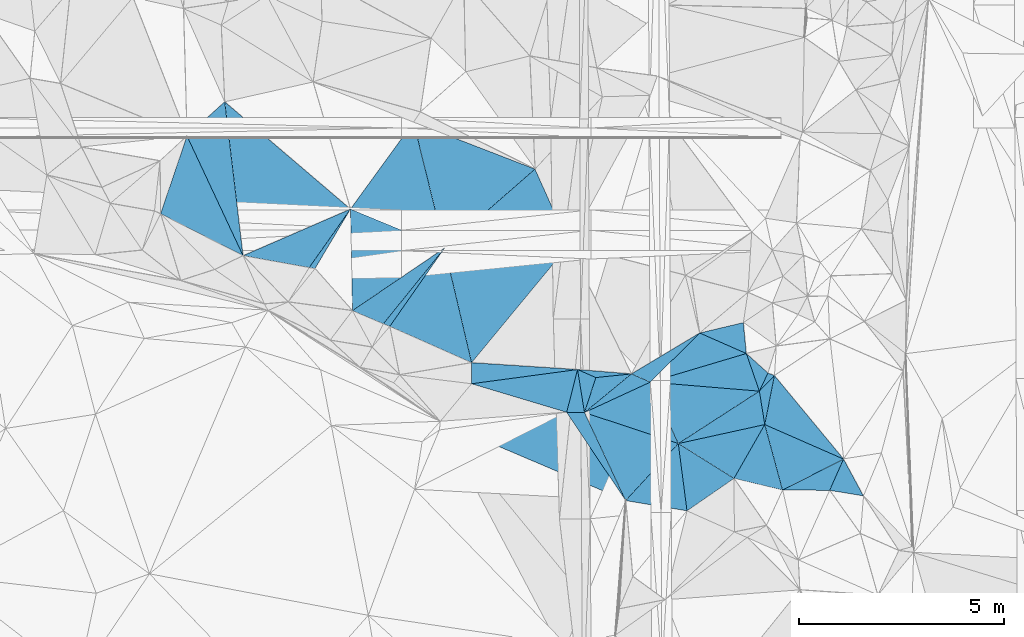
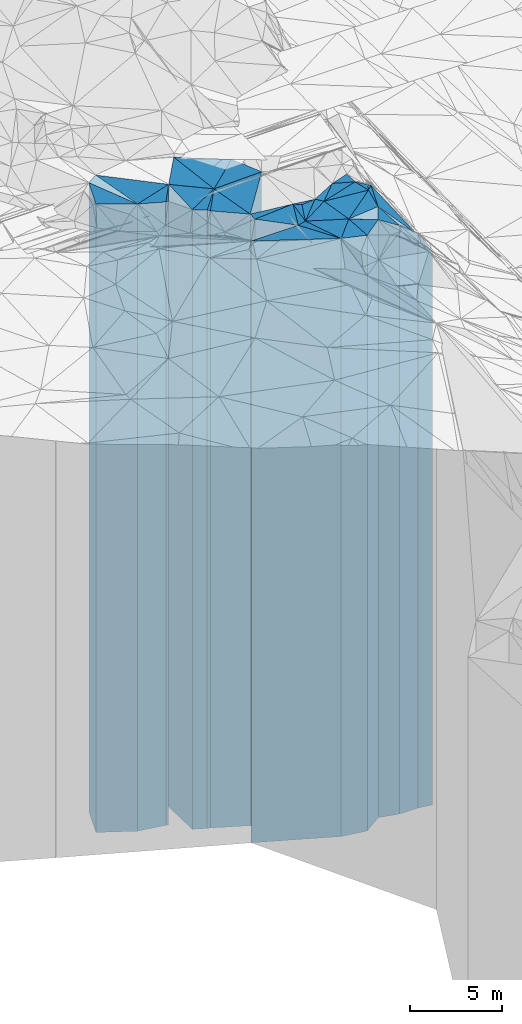
# One storey, part 209 of 275: 41 plates.
"""IFC2X3 building model written with IfcOpenShell, lengths in millimetres."""

from ifc_helpers import new_model, si_unit, frame, origin_with_axes, place, context, subcontext, project, spatial, faceted_brep, material, type_object, element, save


model = new_model("IFC2X3")

# Units and contexts
model_context = context("Model", 3, precision=1e-05, world=origin_with_axes())
body_context = subcontext(model_context, "Body", "Model", "MODEL_VIEW")
ifc_project = project(units=[si_unit("LENGTHUNIT", "METRE", prefix="MILLI"), si_unit("AREAUNIT", "SQUARE_METRE"), si_unit("VOLUMEUNIT", "CUBIC_METRE"), si_unit("MASSUNIT", "GRAM", prefix="KILO"), si_unit("TIMEUNIT", "SECOND"), si_unit("PLANEANGLEUNIT", "RADIAN"), si_unit("SOLIDANGLEUNIT", "STERADIAN"), si_unit("THERMODYNAMICTEMPERATUREUNIT", "DEGREE_CELSIUS"), si_unit("LUMINOUSINTENSITYUNIT", "LUMEN")], contexts=[model_context])

# Site, building, storey
site_placement = place(None, origin_with_axes())
site = spatial("IfcSite", under=ifc_project, at=site_placement, CompositionType="ELEMENT")
building_placement = place(site_placement, origin_with_axes())
building = spatial("IfcBuilding", under=site, at=building_placement, Name="Undefined", CompositionType="ELEMENT")
storey_placement = place(building_placement, origin_with_axes())
storey = spatial("IfcBuildingStorey", under=building, at=storey_placement, Name="Undefined", CompositionType="ELEMENT", Elevation=0.0)

# Plates
ifc_material = material()
plate_type_1 = type_object("IfcPlateType", PredefinedType="NOTDEFINED")
plate_1_placement = place(storey_placement, frame((-114424.275209468, 60931.8089571276, 28569.0), z_axis=(0.670976266904861, -0.741478825894857, 0.0), x_axis=(-0.741478825894864, -0.670976266904855, 0.0)))
element("IfcPlate", 1, at=plate_1_placement, inside=storey, type_object=plate_type_1, material=ifc_material, Name="00", context=body_context, shape_type="Brep", body=[
    faceted_brep([(1.45519152283669e-11, -20741.0, -1.45519152283669e-11), (2189.93041992193, -20941.0, 3088.80297851561), (2189.93041992193, 20741.0, 3088.80297851561), (1.45519152283669e-11, 20741.0, -1.45519152283669e-11), (1242.7791748047, -21071.0, 5.67524693906307e-10), (1242.7791748047, 20741.0, 5.67524693906307e-10)], [[[0, 1, 2, 3]], [[1, 4, 5, 2]], [[4, 0, 3, 5]], [[5, 3, 2]], [[4, 1, 0]]]),
])
plate_type_2 = type_object("IfcPlateType", PredefinedType="NOTDEFINED")
plate_2_placement = place(storey_placement, frame((-112359.67016511, 56880.6972565187, 28519.0), z_axis=(0.170841814937065, 0.985298469636998, 0.0), x_axis=(0.985298469637004, -0.17084181493703, 0.0)))
element("IfcPlate", 2, at=plate_2_placement, inside=storey, type_object=plate_type_2, material=ifc_material, Name="00", context=body_context, shape_type="Brep", body=[
    faceted_brep([(1.45519152283669e-11, -20741.0, -1.45519152283669e-11), (748.845275878848, -20691.0, 1580.89550781251), (748.845275878848, 20691.0, 1580.89550781251), (0.0, 20691.0, 0.0), (144.222045898438, -20761.0, -5.45696821063757e-10), (144.222045898438, 20691.0, -5.45696821063757e-10)], [[[0, 1, 2, 3]], [[1, 4, 5, 2]], [[4, 0, 3, 5]], [[5, 3, 2]], [[4, 1, 0]]]),
])
plate_type_3 = type_object("IfcPlateType", PredefinedType="NOTDEFINED")
plate_3_placement = place(storey_placement, frame((-106011.673109198, 57435.1640076748, 28254.0), z_axis=(-0.912580697493601, -0.408896650221169, 0.0), x_axis=(-0.408896650221169, 0.912580697493601, 0.0)))
element("IfcPlate", 3, at=plate_3_placement, inside=storey, type_object=plate_type_3, material=ifc_material, Name="00", context=body_context, shape_type="Brep", body=[
    faceted_brep([(0.0, -20456.0, 1.45519152283669e-11), (1173.828125, -20426.0, 2804.25170898436), (1173.828125, 20426.0, 2804.25170898436), (0.0, 20426.0, 1.45519152283669e-11), (2030.02465820313, -20456.0, -2.7648638933897e-09), (2030.02465820313, 20426.0, -2.7648638933897e-09)], [[[0, 1, 2, 3]], [[1, 4, 5, 2]], [[4, 0, 3, 5]], [[5, 3, 2]], [[4, 1, 0]]]),
])
plate_type_4 = type_object("IfcPlateType", PredefinedType="NOTDEFINED")
plate_4_placement = place(storey_placement, frame((-109809.448700942, 60435.6473945233, 28254.0), z_axis=(0.809337018100114, -0.58734452507265, 0.0), x_axis=(-0.587344525072653, -0.809337018100111, 0.0)))
element("IfcPlate", 4, at=plate_4_placement, inside=storey, type_object=plate_type_4, material=ifc_material, Name="00", context=body_context, shape_type="Brep", body=[
    faceted_brep([(9.09494701772928e-12, -20936.0, -1.45519152283669e-11), (2043.84008789064, -20426.0, 2420.66479492188), (2043.84008789064, 20426.0, 2420.66479492188), (0.0, 20426.0, 1.45519152283669e-11), (2625.89038085938, -20956.0, 9.66247171163559e-09), (2625.89038085938, 20426.0, 9.66247171163559e-09)], [[[0, 1, 2, 3]], [[1, 4, 5, 2]], [[4, 0, 3, 5]], [[5, 3, 2]], [[4, 1, 0]]]),
])
plate_type_5 = type_object("IfcPlateType", PredefinedType="NOTDEFINED")
plate_5_placement = place(storey_placement, frame((-108391.041459215, 54557.1253951925, 28149.0), z_axis=(-0.77071736266349, 0.637177170721797, 0.0), x_axis=(0.637177170721798, 0.770717362663489, 0.0)))
element("IfcPlate", 5, at=plate_5_placement, inside=storey, type_object=plate_type_5, material=ifc_material, Name="00", context=body_context, shape_type="Brep", body=[
    faceted_brep([(0.0, -20321.0, 0.0), (1739.66088867188, -20531.0, 2294.20581054689), (1739.66088867188, 20321.0, 2294.20581054689), (0.0, 20321.0, 0.0), (3734.23364257813, -20561.0, 7.71251507103443e-09), (3734.23364257813, 20321.0, 7.71251507103443e-09)], [[[0, 1, 2, 3]], [[1, 4, 5, 2]], [[4, 0, 3, 5]], [[5, 3, 2]], [[4, 1, 0]]]),
])
plate_type_6 = type_object("IfcPlateType", PredefinedType="NOTDEFINED")
plate_6_placement = place(storey_placement, frame((-113975.54879864, 57172.1354861696, 28519.0), z_axis=(-0.397990849921517, 0.91738938481909, 0.0), x_axis=(0.91738938481909, 0.397990849921517, 0.0)))
element("IfcPlate", 6, at=plate_6_placement, inside=storey, type_object=plate_type_6, material=ifc_material, Name="00", context=body_context, shape_type="Brep", body=[
    faceted_brep([(-1.45519152283669e-11, -20991.0, 0.0), (1084.65881347655, -20791.0, 3627.67358398439), (1084.65881347655, 20691.0, 3627.67358398439), (0.0, 20691.0, 0.0), (2860.06982421874, -20691.0, 3.23052518069744e-09), (2860.06982421874, 20691.0, 3.23052518069744e-09)], [[[0, 1, 2, 3]], [[1, 4, 5, 2]], [[4, 0, 3, 5]], [[5, 3, 2]], [[4, 1, 0]]]),
])
plate_type_7 = type_object("IfcPlateType", PredefinedType="NOTDEFINED")
plate_7_placement = place(storey_placement, frame((-104025.95095473, 54081.746717021, 27959.0), z_axis=(-0.285407885057941, 0.95840614519459, 0.0), x_axis=(0.958406145194588, 0.285407885057947, 0.0)))
element("IfcPlate", 7, at=plate_7_placement, inside=storey, type_object=plate_type_7, material=ifc_material, Name="00", context=body_context, shape_type="Brep", body=[
    faceted_brep([(0.0, -20131.0, 7.27595761418343e-12), (1500.02416992188, -20161.0, 806.304809570313), (1500.02416992188, 20131.0, 806.304809570313), (1.45519152283669e-11, 20131.0, 0.0), (2449.69384765626, -20171.0, 1.89174897968769e-10), (2449.69384765626, 20131.0, 1.89174897968769e-10)], [[[0, 1, 2, 3]], [[1, 4, 5, 2]], [[4, 0, 3, 5]], [[5, 3, 2]], [[4, 1, 0]]]),
])
plate_type_8 = type_object("IfcPlateType", PredefinedType="NOTDEFINED")
plate_8_placement = place(storey_placement, frame((-101359.051632054, 53861.41060398, 27929.0), z_axis=(-0.904147253795478, 0.427220953903359, 0.0), x_axis=(0.42722095390336, 0.904147253795477, 0.0)))
element("IfcPlate", 8, at=plate_8_placement, inside=storey, type_object=plate_type_8, material=ifc_material, Name="00", context=body_context, shape_type="Brep", body=[
    faceted_brep([(-1.18234311230481e-11, -20101.0, 0.0), (695.036437988269, -20201.0, 681.340148925781), (695.036437988269, 20101.0, 681.340148925781), (-1.18234311230481e-11, 20101.0, 0.0), (489.182983398433, -20131.0, -1.64436642080545e-09), (489.182983398433, 20101.0, -1.64436642080545e-09)], [[[0, 1, 2, 3]], [[1, 4, 5, 2]], [[4, 0, 3, 5]], [[5, 3, 2]], [[4, 1, 0]]]),
])
plate_type_9 = type_object("IfcPlateType", PredefinedType="NOTDEFINED")
plate_9_placement = place(storey_placement, frame((-101749.814494169, 55536.464151062, 27974.0), z_axis=(0.231099677077141, -0.972930079324738, 0.0), x_axis=(-0.97293007932474, -0.231099677077134, 0.0)))
element("IfcPlate", 9, at=plate_9_placement, inside=storey, type_object=plate_type_9, material=ifc_material, Name="00", context=body_context, shape_type="Brep", body=[
    faceted_brep([(0.0, -20246.0, 0.0), (104.883415222153, -20156.0, 751.664489746079), (104.883415222153, 20146.0, 751.664489746079), (2.91038304567337e-11, 20146.0, 1.09139364212751e-11), (1098.3624267578, -20146.0, 3.65253072232008e-09), (1098.3624267578, 20146.0, 3.66708263754845e-09)], [[[0, 1, 2, 3]], [[1, 4, 5, 2]], [[4, 0, 3, 5]], [[5, 3, 2]], [[4, 1, 0]]]),
])
plate_type_10 = type_object("IfcPlateType", PredefinedType="NOTDEFINED")
plate_10_placement = place(storey_placement, frame((-101227.597226745, 53044.8202909558, 26614.0), z_axis=(0.401196459925375, 0.915992030829607, 0.0), x_axis=(0.915992030829608, -0.401196459925371, 0.0)))
element("IfcPlate", 10, at=plate_10_placement, inside=storey, type_object=plate_type_10, material=ifc_material, Name="00", context=body_context, shape_type="Brep", body=[
    faceted_brep([(-1.45519152283669e-11, -20766.0, -1.45519152283669e-11), (-264.495147705093, -21386.0, 1191.65527343749), (-264.495147705093, 18786.0, 1191.65527343749), (0.0, 18786.0, -1.81898940354586e-12), (2102.11791992186, -18786.0, 4.60750015918165e-09), (2102.11791992186, 18786.0, 4.60750015918165e-09)], [[[0, 1, 2, 3]], [[1, 4, 5, 2]], [[4, 0, 3, 5]], [[5, 3, 2]], [[4, 1, 0]]]),
])
plate_type_11 = type_object("IfcPlateType", PredefinedType="NOTDEFINED")
plate_11_placement = place(storey_placement, frame((-101678.149306749, 54780.9086594453, 27929.0), z_axis=(0.285407885057941, -0.95840614519459, 0.0), x_axis=(-0.958406145194588, -0.285407885057947, 0.0)))
element("IfcPlate", 11, at=plate_11_placement, inside=storey, type_object=plate_type_11, material=ifc_material, Name="00", context=body_context, shape_type="Brep", body=[
    faceted_brep([(-7.27595761418343e-12, -20201.0, 0.0), (-43.3931770324853, -20101.0, 972.325561523423), (-43.3931770324853, 20101.0, 972.325561523423), (-1.18234311230481e-11, 20101.0, 0.0), (2449.69384765624, -20161.0, 2.18278728425503e-10), (2449.69384765624, 20101.0, 2.18278728425503e-10)], [[[0, 1, 2, 3]], [[1, 4, 5, 2]], [[4, 0, 3, 5]], [[5, 3, 2]], [[4, 1, 0]]]),
])
plate_type_12 = type_object("IfcPlateType", PredefinedType="NOTDEFINED")
plate_12_placement = place(storey_placement, frame((-113975.54879864, 57172.1354861696, 28519.0), z_axis=(0.177495184991706, 0.984121668953976, 0.0), x_axis=(0.984121668953977, -0.177495184991705, 0.0)))
element("IfcPlate", 12, at=plate_12_placement, inside=storey, type_object=plate_type_12, material=ifc_material, Name="00", context=body_context, shape_type="Brep", body=[
    faceted_brep([(-1.45519152283669e-11, -20991.0, 0.0), (2380.09667968749, -20691.0, 1585.91906738281), (2380.09667968749, 20691.0, 1585.91906738281), (0.0, 20691.0, 0.0), (1641.95007324217, -20741.0, 3.18686943501234e-09), (1641.95007324217, 20691.0, 3.18686943501234e-09)], [[[0, 1, 2, 3]], [[1, 4, 5, 2]], [[4, 0, 3, 5]], [[5, 3, 2]], [[4, 1, 0]]]),
])
plate_type_13 = type_object("IfcPlateType", PredefinedType="NOTDEFINED")
plate_13_placement = place(storey_placement, frame((-109050.753459271, 57359.7277710179, 28254.0), z_axis=(-0.381855316813604, -0.924222114548869, 0.0), x_axis=(-0.924222114548867, 0.381855316813607, 0.0)))
element("IfcPlate", 13, at=plate_13_placement, inside=storey, type_object=plate_type_13, material=ifc_material, Name="00", context=body_context, shape_type="Brep", body=[
    faceted_brep([(0.0, -20426.0, -1.45519152283669e-11), (1497.2333984375, -20766.0, 2276.13525390625), (1497.2333984375, 20426.0, 2276.13525390625), (0.0, 20426.0, 1.45519152283669e-11), (2489.65869140625, -20956.0, -4.47471393272281e-09), (2489.65869140625, 20426.0, -4.47471393272281e-09)], [[[0, 1, 2, 3]], [[1, 4, 5, 2]], [[4, 0, 3, 5]], [[5, 3, 2]], [[4, 1, 0]]]),
])
plate_type_14 = type_object("IfcPlateType", PredefinedType="NOTDEFINED")
plate_14_placement = place(storey_placement, frame((-103340.405427795, 52580.7712573621, 27604.0), z_axis=(-0.2145227860623, 0.976718984283642, 0.0), x_axis=(0.976718984283642, 0.214522786062299, 0.0)))
element("IfcPlate", 14, at=plate_14_placement, inside=storey, type_object=plate_type_14, material=ifc_material, Name="00", context=body_context, shape_type="Brep", body=[
    faceted_brep([(-1.45519152283669e-11, -19976.0, 0.0), (2209.9521484375, -20426.0, 825.779235839844), (2209.9521484375, 19776.0, 825.779235839844), (-1.45519152283669e-11, 19776.0, 0.0), (2163.16894531249, -19776.0, -3.36149241775274e-09), (2163.16894531249, 19776.0, -3.36149241775274e-09)], [[[0, 1, 2, 3]], [[1, 4, 5, 2]], [[4, 0, 3, 5]], [[5, 3, 2]], [[4, 1, 0]]]),
])
plate_type_15 = type_object("IfcPlateType", PredefinedType="NOTDEFINED")
plate_15_placement = place(storey_placement, frame((-101359.051632054, 53861.41060398, 27604.0), z_axis=(0.987289296012235, 0.158933464001971, 0.0), x_axis=(0.158933464001974, -0.987289296012234, 0.0)))
element("IfcPlate", 15, at=plate_15_placement, inside=storey, type_object=plate_type_15, material=ifc_material, Name="00", context=body_context, shape_type="Brep", body=[
    faceted_brep([(0.0, -20426.0, -1.45519152283669e-11), (-317.856262207046, -20396.0, 423.163543701157), (-317.856262207046, 19776.0, 423.163543701157), (-1.45519152283669e-11, 19776.0, 0.0), (827.103393554673, -19776.0, -1.86264514923096e-09), (827.103393554673, 19776.0, -1.86264514923096e-09)], [[[0, 1, 2, 3]], [[1, 4, 5, 2]], [[4, 0, 3, 5]], [[5, 3, 2]], [[4, 1, 0]]]),
])
plate_type_16 = type_object("IfcPlateType", PredefinedType="NOTDEFINED")
plate_16_placement = place(storey_placement, frame((-100793.03330737, 51443.8036764334, 26614.0), z_axis=(-0.453027820121401, 0.891496379238891, 0.0), x_axis=(0.891496379238891, 0.4530278201214, 0.0)))
element("IfcPlate", 16, at=plate_16_placement, inside=storey, type_object=plate_type_16, material=ifc_material, Name="00", context=body_context, shape_type="Brep", body=[
    faceted_brep([(-1.45519152283669e-11, -20316.0, 0.0), (337.892913818359, -20766.0, 1624.17004394531), (337.892913818359, 18786.0, 1624.17004394531), (0.0, 18786.0, -1.81898940354586e-12), (1672.42333984375, -18786.0, -1.94995664060116e-09), (1672.42333984375, 18786.0, -1.94995664060116e-09)], [[[0, 1, 2, 3]], [[1, 4, 5, 2]], [[4, 0, 3, 5]], [[5, 3, 2]], [[4, 1, 0]]]),
])
plate_type_17 = type_object("IfcPlateType", PredefinedType="NOTDEFINED")
plate_17_placement = place(storey_placement, frame((-100991.784790361, 54242.4815514324, 27914.0), z_axis=(-0.360757109901238, -0.932659802744659, 0.0), x_axis=(-0.932659802744667, 0.360757109901216, 0.0)))
element("IfcPlate", 17, at=plate_17_placement, inside=storey, type_object=plate_type_17, material=ifc_material, Name="00", context=body_context, shape_type="Brep", body=[
    faceted_brep([(0.0, -20086.0, 0.0), (205.060974121079, -20116.0, 487.903686523438), (205.060974121079, 20086.0, 487.903686523438), (0.0, 20086.0, 0.0), (169.705627441406, -20146.0, 6.83940015733242e-10), (169.705627441406, 20086.0, 6.83940015733242e-10)], [[[0, 1, 2, 3]], [[1, 4, 5, 2]], [[4, 0, 3, 5]], [[5, 3, 2]], [[4, 1, 0]]]),
])
plate_type_18 = type_object("IfcPlateType", PredefinedType="NOTDEFINED")
plate_18_placement = place(storey_placement, frame((-99302.0739093872, 52201.4579997015, 26614.0), z_axis=(0.453027820121401, -0.891496379238891, 0.0), x_axis=(-0.891496379238893, -0.453027820121396, 0.0)))
element("IfcPlate", 18, at=plate_18_placement, inside=storey, type_object=plate_type_18, material=ifc_material, Name="00", context=body_context, shape_type="Brep", body=[
    faceted_brep([(0.0, -18786.0, 0.0), (649.237487792961, -19366.0, 525.823791503906), (649.237487792961, 18786.0, 525.823791503906), (0.0, 18786.0, -1.81898940354586e-12), (1672.42333984374, -20316.0, -1.96450855582953e-09), (1672.42333984375, 18786.0, -1.94995664060116e-09)], [[[0, 1, 2, 3]], [[1, 4, 5, 2]], [[4, 0, 3, 5]], [[5, 3, 2]], [[4, 1, 0]]]),
])
plate_type_19 = type_object("IfcPlateType", PredefinedType="NOTDEFINED")
plate_19_placement = place(storey_placement, frame((-105632.632516036, 53338.5277986937, 27704.0), z_axis=(0.313871074084043, 0.949465612254246, 0.0), x_axis=(0.949465612254244, -0.313871074084048, 0.0)))
element("IfcPlate", 19, at=plate_19_placement, inside=storey, type_object=plate_type_19, material=ifc_material, Name="00", context=body_context, shape_type="Brep", body=[
    faceted_brep([(0.0, -20076.0, 0.0), (1292.21398925783, -20386.0, 1209.95166015625), (1292.21398925783, 19876.0, 1209.95166015625), (1.45519152283669e-11, 19876.0, 3.63797880709171e-12), (2414.22875976564, -19876.0, -6.62475940771401e-09), (2414.22875976564, 19876.0, -6.62475940771401e-09)], [[[0, 1, 2, 3]], [[1, 4, 5, 2]], [[4, 0, 3, 5]], [[5, 3, 2]], [[4, 1, 0]]]),
])
plate_type_20 = type_object("IfcPlateType", PredefinedType="NOTDEFINED")
plate_20_placement = place(storey_placement, frame((-102818.444328002, 55282.6329507697, 27959.0), z_axis=(0.514166750066084, -0.857690243110227, 0.0), x_axis=(-0.85769024311023, -0.51416675006608, 0.0)))
element("IfcPlate", 20, at=plate_20_placement, inside=storey, type_object=plate_type_20, material=ifc_material, Name="00", context=body_context, shape_type="Brep", body=[
    faceted_brep([(-3.63797880709171e-12, -20161.0, 0.0), (1653.12243652342, -20131.0, 409.128662109375), (1653.12243652342, 20131.0, 409.128662109375), (1.45519152283669e-11, 20131.0, 0.0), (1944.86499023438, -20301.0, 1.0986695997417e-08), (1944.86499023438, 20131.0, 1.0986695997417e-08)], [[[0, 1, 2, 3]], [[1, 4, 5, 2]], [[4, 0, 3, 5]], [[5, 3, 2]], [[4, 1, 0]]]),
])
plate_type_21 = type_object("IfcPlateType", PredefinedType="NOTDEFINED")
plate_21_placement = place(storey_placement, frame((-105632.632516036, 53338.5277986937, 27804.0), z_axis=(-0.951100424197907, 0.308881827064269, 0.0), x_axis=(0.308881827064278, 0.951100424197904, 0.0)))
element("IfcPlate", 21, at=plate_21_placement, inside=storey, type_object=plate_type_21, material=ifc_material, Name="00", context=body_context, shape_type="Brep", body=[
    faceted_brep([(-1.45519152283669e-11, -19976.0, 0.0), (947.421325683605, -20536.0, 485.996765136719), (947.421325683605, 19976.0, 485.996765136719), (1.09139364212751e-11, 19976.0, 0.0), (899.388671875007, -20456.0, -2.21189111471176e-09), (899.388671875007, 19976.0, -2.21189111471176e-09)], [[[0, 1, 2, 3]], [[1, 4, 5, 2]], [[4, 0, 3, 5]], [[5, 3, 2]], [[4, 1, 0]]]),
])
plate_type_22 = type_object("IfcPlateType", PredefinedType="NOTDEFINED")
plate_22_placement = place(storey_placement, frame((-105802.223031823, 54389.7361781101, 27740.0), z_axis=(0.969370848409617, -0.245601625103783, 0.0), x_axis=(-0.245601625103788, -0.969370848409616, 0.0)))
element("IfcPlate", 22, at=plate_22_placement, inside=storey, type_object=plate_type_22, material=ifc_material, Name="00", context=body_context, shape_type="Brep", body=[
    faceted_brep([(-7.27595761418343e-12, -20600.0, -2.91038304567337e-11), (977.359069824219, -20040.0, 422.574584960908), (977.359069824219, 19912.0, 422.574584960908), (-7.27595761418343e-12, 19912.0, -2.91038304567337e-11), (1078.43688964843, -19912.0, -6.83940015733242e-10), (1078.43688964843, 19912.0, -6.83940015733242e-10)], [[[0, 1, 2, 3]], [[1, 4, 5, 2]], [[4, 0, 3, 5]], [[5, 3, 2]], [[4, 1, 0]]]),
])
plate_type_23 = type_object("IfcPlateType", PredefinedType="NOTDEFINED")
plate_23_placement = place(storey_placement, frame((-105802.223031823, 54389.7361781101, 28044.0), z_axis=(0.400928765088184, 0.916109232201523, 0.0), x_axis=(0.91610923220154, -0.400928765088145, 0.0)))
element("IfcPlate", 23, at=plate_23_placement, inside=storey, type_object=plate_type_23, material=ifc_material, Name="00", context=body_context, shape_type="Brep", body=[
    faceted_brep([(-1.45519152283669e-11, -20296.0, 9.09494701772928e-12), (1248.24768066405, -20216.0, 429.392272949235), (1248.24768066405, 20216.0, 429.392272949235), (0.0, 20216.0, 0.0), (488.364624023423, -20216.0, -2.49383447226137e-09), (488.364624023423, 20216.0, -2.49383447226137e-09)], [[[0, 1, 2, 3]], [[1, 4, 5, 2]], [[4, 0, 3, 5]], [[5, 3, 2]], [[4, 1, 0]]]),
])
plate_type_24 = type_object("IfcPlateType", PredefinedType="NOTDEFINED")
plate_24_placement = place(storey_placement, frame((-101227.597226745, 53044.8202909558, 27379.0), z_axis=(0.868369191321728, -0.495918287183734, 0.0), x_axis=(-0.495918287183737, -0.868369191321726, 0.0)))
element("IfcPlate", 24, at=plate_24_placement, inside=storey, type_object=plate_type_24, material=ifc_material, Name="00", context=body_context, shape_type="Brep", body=[
    faceted_brep([(8.18545231595635e-12, -20001.0, 0.0), (1174.76525878908, -19551.0, 1171.33532714844), (1174.76525878908, 19551.0, 1171.33532714844), (8.18545231595635e-12, 19551.0, 0.0), (1516.04748535157, -20191.0, -5.1804818212986e-09), (1516.04748535157, 19551.0, -5.1804818212986e-09)], [[[0, 1, 2, 3]], [[1, 4, 5, 2]], [[4, 0, 3, 5]], [[5, 3, 2]], [[4, 1, 0]]]),
])
plate_type_25 = type_object("IfcPlateType", PredefinedType="NOTDEFINED")
plate_25_placement = place(storey_placement, frame((-103127.269773389, 50936.516656389, 27624.0), z_axis=(-0.567831637088504, 0.823144721128301, 0.0), x_axis=(0.823144721128301, 0.567831637088506, 0.0)))
element("IfcPlate", 25, at=plate_25_placement, inside=storey, type_object=plate_type_25, material=ifc_material, Name="00", context=body_context, shape_type="Brep", body=[
    faceted_brep([(-7.27595761418343e-12, -19796.0, -1.45519152283669e-11), (758.218322753892, -19956.0, 1474.48461914063), (758.218322753892, 19796.0, 1474.48461914063), (-7.27595761418343e-12, 19796.0, -1.45519152283669e-11), (1394.45324707031, -19946.0, -1.19325704872608e-09), (1394.45324707031, 19796.0, -1.19325704872608e-09)], [[[0, 1, 2, 3]], [[1, 4, 5, 2]], [[4, 0, 3, 5]], [[5, 3, 2]], [[4, 1, 0]]]),
])
plate_type_26 = type_object("IfcPlateType", PredefinedType="NOTDEFINED")
plate_26_placement = place(storey_placement, frame((-101359.051632054, 53861.41060398, 27704.0), z_axis=(-0.0823382969590661, -0.99660443750461, 0.0), x_axis=(-0.99660443750461, 0.0823382969590713, 0.0)))
element("IfcPlate", 26, at=plate_26_placement, inside=storey, type_object=plate_type_26, material=ifc_material, Name="00", context=body_context, shape_type="Brep", body=[
    faceted_brep([(1.45519152283669e-11, -20326.0, -7.27595761418343e-12), (1869.18029785159, -19876.0, 1439.43212890624), (1869.18029785159, 19876.0, 1439.43212890624), (1.45519152283669e-11, 19876.0, 3.63797880709171e-12), (2675.98583984375, -20386.0, 5.65341906622052e-09), (2675.98583984375, 19876.0, 5.65341906622052e-09)], [[[0, 1, 2, 3]], [[1, 4, 5, 2]], [[4, 0, 3, 5]], [[5, 3, 2]], [[4, 1, 0]]]),
])
plate_type_27 = type_object("IfcPlateType", PredefinedType="NOTDEFINED")
plate_27_placement = place(storey_placement, frame((-99302.0739093872, 52201.4579997015, 26224.0), z_axis=(0.913136541977907, -0.40765384299014, 0.0), x_axis=(-0.407653842990145, -0.913136541977905, 0.0)))
element("IfcPlate", 27, at=plate_27_placement, inside=storey, type_object=plate_type_27, material=ifc_material, Name="00", context=body_context, shape_type="Brep", body=[
    faceted_brep([(1.81898940354586e-12, -19176.0, -1.45519152283669e-11), (624.323791503901, -18396.0, 810.567565917969), (624.323791503901, 18396.0, 810.567565917969), (-1.45519152283669e-11, 18396.0, 1.45519152283669e-11), (835.463928222658, -19756.0, 7.71251507103443e-10), (835.463928222658, 18396.0, 7.71251507103443e-10)], [[[0, 1, 2, 3]], [[1, 4, 5, 2]], [[4, 0, 3, 5]], [[5, 3, 2]], [[4, 1, 0]]]),
])
plate_type_28 = type_object("IfcPlateType", PredefinedType="NOTDEFINED")
plate_28_placement = place(storey_placement, frame((-103340.405427795, 52580.7712573621, 27604.0), z_axis=(0.530819073017113, 0.847485169027313, 0.0), x_axis=(0.847485169027316, -0.530819073017108, 0.0)))
element("IfcPlate", 28, at=plate_28_placement, inside=storey, type_object=plate_type_28, material=ifc_material, Name="00", context=body_context, shape_type="Brep", body=[
    faceted_brep([(-1.45519152283669e-11, -19976.0, 0.0), (1544.24755859375, -19776.0, 1514.79357910157), (1544.24755859375, 19776.0, 1514.79357910157), (-1.45519152283669e-11, 19776.0, 0.0), (1605.8953857422, -19966.0, 2.19552021007985e-09), (1605.8953857422, 19776.0, 2.19552021007985e-09)], [[[0, 1, 2, 3]], [[1, 4, 5, 2]], [[4, 0, 3, 5]], [[5, 3, 2]], [[4, 1, 0]]]),
])
plate_type_29 = type_object("IfcPlateType", PredefinedType="NOTDEFINED")
plate_29_placement = place(storey_placement, frame((-104486.536091256, 54282.6480162005, 27804.0), z_axis=(0.101638505019443, -0.994821398190355, 0.0), x_axis=(-0.994821398190354, -0.101638505019448, 0.0)))
element("IfcPlate", 29, at=plate_29_placement, inside=storey, type_object=plate_type_29, material=ifc_material, Name="00", context=body_context, shape_type="Brep", body=[
    faceted_brep([(0.0, -20456.0, 1.45519152283669e-11), (1236.12023925781, -19976.0, 822.743469238289), (1236.12023925781, 19976.0, 822.743469238289), (1.09139364212751e-11, 19976.0, 0.0), (872.811523437515, -20456.0, 1.96450855582953e-10), (872.811523437515, 19976.0, 1.96450855582953e-10)], [[[0, 1, 2, 3]], [[1, 4, 5, 2]], [[4, 0, 3, 5]], [[5, 3, 2]], [[4, 1, 0]]]),
])
plate_type_30 = type_object("IfcPlateType", PredefinedType="NOTDEFINED")
plate_30_placement = place(storey_placement, frame((-108393.037823814, 54042.34775919, 27740.0), z_axis=(0.287435577114378, 0.957799973381146, 0.0), x_axis=(0.957799973381145, -0.287435577114382, 0.0)))
element("IfcPlate", 30, at=plate_30_placement, inside=storey, type_object=plate_type_30, material=ifc_material, Name="00", context=body_context, shape_type="Brep", body=[
    faceted_brep([(0.0, -20710.0, 3.63797880709171e-12), (2381.63061523439, -20600.0, 1077.42102050782), (2381.63061523439, 19912.0, 1077.42102050782), (-7.27595761418343e-12, 19912.0, -2.91038304567337e-11), (2428.4287109375, -19912.0, 6.94126356393099e-09), (2428.4287109375, 19912.0, 6.94126356393099e-09)], [[[0, 1, 2, 3]], [[1, 4, 5, 2]], [[4, 0, 3, 5]], [[5, 3, 2]], [[4, 1, 0]]]),
])
plate_type_31 = type_object("IfcPlateType", PredefinedType="NOTDEFINED")
plate_31_placement = place(storey_placement, frame((-105802.223031823, 54389.7361781101, 28084.0), z_axis=(-0.0645238010241575, -0.997916168373574, 0.0), x_axis=(-0.997916168373574, 0.0645238010241554, 0.0)))
element("IfcPlate", 31, at=plate_31_placement, inside=storey, type_object=plate_type_31, material=ifc_material, Name="00", context=body_context, shape_type="Brep", body=[
    faceted_brep([(1.45519152283669e-11, -20256.0, 0.0), (2563.00122070314, -20366.0, 513.833740234368), (2563.00122070314, 20256.0, 513.833740234368), (-1.45519152283669e-11, 20256.0, 7.27595761418343e-12), (2594.22436523438, -20386.0, 3.47790773957968e-09), (2594.22436523436, 20256.0, 3.48518369719386e-09)], [[[0, 1, 2, 3]], [[1, 4, 5, 2]], [[4, 0, 3, 5]], [[5, 3, 2]], [[4, 1, 0]]]),
])
plate_type_32 = type_object("IfcPlateType", PredefinedType="NOTDEFINED")
plate_32_placement = place(storey_placement, frame((-110548.879326198, 55505.5112553854, 28254.0), z_axis=(0.360757109901238, 0.932659802744659, 0.0), x_axis=(0.932659802744688, -0.360757109901163, 0.0)))
element("IfcPlate", 32, at=plate_32_placement, inside=storey, type_object=plate_type_32, material=ifc_material, Name="00", context=body_context, shape_type="Brep", body=[
    faceted_brep([(0.0, -20656.0, 1.45519152283669e-11), (728.320007324204, -20426.0, 2269.81274414063), (728.320007324204, 20426.0, 2269.81274414063), (0.0, 20426.0, 1.45519152283669e-11), (169.705627441406, -20596.0, 6.47560227662325e-10), (169.705627441406, 20426.0, 6.47560227662325e-10)], [[[0, 1, 2, 3]], [[1, 4, 5, 2]], [[4, 0, 3, 5]], [[5, 3, 2]], [[4, 1, 0]]]),
])
plate_type_33 = type_object("IfcPlateType", PredefinedType="NOTDEFINED")
plate_33_placement = place(storey_placement, frame((-111303.684056734, 55827.7996646714, 28254.0), z_axis=(0.392684399118446, 0.919673291277389, 0.0), x_axis=(0.919673291277392, -0.392684399118439, 0.0)))
element("IfcPlate", 33, at=plate_33_placement, inside=storey, type_object=plate_type_33, material=ifc_material, Name="00", context=body_context, shape_type="Brep", body=[
    faceted_brep([(-1.45519152283669e-11, -20766.0, -1.45519152283669e-11), (1470.39587402341, -20426.0, 2293.56396484375), (1470.39587402341, 20426.0, 2293.56396484375), (0.0, 20426.0, 1.45519152283669e-11), (820.731384277344, -20656.0, 2.01544025912881e-09), (820.731384277344, 20426.0, 2.01544025912881e-09)], [[[0, 1, 2, 3]], [[1, 4, 5, 2]], [[4, 0, 3, 5]], [[5, 3, 2]], [[4, 1, 0]]]),
])
plate_type_34 = type_object("IfcPlateType", PredefinedType="NOTDEFINED")
plate_34_placement = place(storey_placement, frame((-113975.54879864, 57172.1354861696, 28669.0), z_axis=(-0.905607221349675, -0.424117390163761, 0.0), x_axis=(-0.42411739016376, 0.905607221349676, 0.0)))
element("IfcPlate", 34, at=plate_34_placement, inside=storey, type_object=plate_type_34, material=ifc_material, Name="00", context=body_context, shape_type="Brep", body=[
    faceted_brep([(-2.91038304567337e-11, -20841.0, 0.0), (1780.57263183594, -20921.0, 1391.74755859375), (1780.57263183594, 20841.0, 1391.74755859375), (0.0, 20841.0, -1.45519152283669e-11), (3230.75854492189, -20971.0, 1.09139364212751e-09), (3230.75854492189, 20841.0, 1.09139364212751e-09)], [[[0, 1, 2, 3]], [[1, 4, 5, 2]], [[4, 0, 3, 5]], [[5, 3, 2]], [[4, 1, 0]]]),
])
plate_type_35 = type_object("IfcPlateType", PredefinedType="NOTDEFINED")
plate_35_placement = place(storey_placement, frame((-109050.753459271, 57359.7277710179, 28149.0), z_axis=(0.819424627744647, -0.573186949821388, 0.0), x_axis=(-0.573186949821383, -0.819424627744651, 0.0)))
element("IfcPlate", 35, at=plate_35_placement, inside=storey, type_object=plate_type_35, material=ifc_material, Name="00", context=body_context, shape_type="Brep", body=[
    faceted_brep([(0.0, -20531.0, 0.0), (1918.38305664063, -20321.0, 2146.9992675781), (1918.38305664063, 20321.0, 2146.9992675781), (0.0, 20321.0, 0.0), (2337.54150390626, -20701.0, -4.61295712739229e-09), (2337.54150390626, 20321.0, -4.61295712739229e-09)], [[[0, 1, 2, 3]], [[1, 4, 5, 2]], [[4, 0, 3, 5]], [[5, 3, 2]], [[4, 1, 0]]]),
])
plate_type_36 = type_object("IfcPlateType", PredefinedType="NOTDEFINED")
plate_36_placement = place(storey_placement, frame((-103340.405427795, 52580.7712573621, 27704.0), z_axis=(-0.313871074084043, -0.949465612254246, 0.0), x_axis=(-0.949465612254244, 0.313871074084048, 0.0)))
element("IfcPlate", 36, at=plate_36_placement, inside=storey, type_object=plate_type_36, material=ifc_material, Name="00", context=body_context, shape_type="Brep", body=[
    faceted_brep([(0.0, -19876.0, 0.0), (783.409667968765, -19876.0, 1725.95080566407), (783.409667968765, 19876.0, 1725.95080566407), (1.45519152283669e-11, 19876.0, 3.63797880709171e-12), (2414.22875976564, -20076.0, -6.63203536532819e-09), (2414.22875976564, 19876.0, -6.62475940771401e-09)], [[[0, 1, 2, 3]], [[1, 4, 5, 2]], [[4, 0, 3, 5]], [[5, 3, 2]], [[4, 1, 0]]]),
])
plate_type_37 = type_object("IfcPlateType", PredefinedType="NOTDEFINED")
plate_37_placement = place(storey_placement, frame((-105632.632516036, 53338.5277986937, 27704.0), z_axis=(-0.0133560829939355, -0.999910803545526, 0.0), x_axis=(-0.999910803545526, 0.0133560829939318, 0.0)))
element("IfcPlate", 37, at=plate_37_placement, inside=storey, type_object=plate_type_37, material=ifc_material, Name="00", context=body_context, shape_type="Brep", body=[
    faceted_brep([(0.0, -20076.0, 0.0), (-1035.31433105467, -19876.0, 2136.96069335937), (-1035.31433105467, 19876.0, 2136.96069335937), (1.45519152283669e-11, 19876.0, 3.63797880709171e-12), (434.495117187515, -19948.0, -4.80213202536106e-10), (434.495117187515, 19876.0, -4.80213202536106e-10)], [[[0, 1, 2, 3]], [[1, 4, 5, 2]], [[4, 0, 3, 5]], [[5, 3, 2]], [[4, 1, 0]]]),
])
plate_type_38 = type_object("IfcPlateType", PredefinedType="NOTDEFINED")
plate_38_placement = place(storey_placement, frame((-104625.951987885, 51187.9299017727, 27704.0), z_axis=(-0.831420493870912, -0.555643736913725, 0.0), x_axis=(-0.555643736913728, 0.83142049387091, 0.0)))
element("IfcPlate", 38, at=plate_38_placement, inside=storey, type_object=plate_type_38, material=ifc_material, Name="00", context=body_context, shape_type="Brep", body=[
    faceted_brep([(0.0, -19876.0, 0.0), (4123.86083984374, -20117.0, 2695.00781250001), (4123.86083984374, 19876.0, 2695.00781250001), (1.45519152283669e-11, 19876.0, 3.63797880709171e-12), (2593.634765625, -19948.0, 2.87400325760245e-09), (2593.634765625, 19876.0, 2.87400325760245e-09)], [[[0, 1, 2, 3]], [[1, 4, 5, 2]], [[4, 0, 3, 5]], [[5, 3, 2]], [[4, 1, 0]]]),
])
plate_type_39 = type_object("IfcPlateType", PredefinedType="NOTDEFINED")
plate_39_placement = place(storey_placement, frame((-104025.95095473, 54081.746717021, 27804.0), z_axis=(-0.399808528152067, -0.916598680348645, 0.0), x_axis=(-0.91659867998218, 0.399808528992223, 0.0)))
element("IfcPlate", 39, at=plate_39_placement, inside=storey, type_object=plate_type_39, material=ifc_material, Name="00", context=body_context, shape_type="Brep", body=[
    faceted_brep([(-1.09139364212751e-11, -20286.0, -1.45519152283669e-11), (1175.53698851791, -19976.0, 1323.59851074218), (1175.53698851791, 19976.0, 1323.59851074218), (1.09139364212751e-11, 19976.0, 0.0), (502.493774414063, -20456.0, -2.91038304567337e-11), (502.493774414063, 19976.0, -2.91038304567337e-11)], [[[0, 1, 2, 3]], [[1, 4, 5, 2]], [[4, 0, 3, 5]], [[5, 3, 2]], [[4, 1, 0]]]),
])
plate_type_40 = type_object("IfcPlateType", PredefinedType="NOTDEFINED")
plate_40_placement = place(storey_placement, frame((-103340.405427795, 52580.7712573621, 27624.0), z_axis=(0.734843714948945, -0.678236473952879, 0.0), x_axis=(-0.678236473952877, -0.734843714948946, 0.0)))
element("IfcPlate", 40, at=plate_40_placement, inside=storey, type_object=plate_type_40, material=ifc_material, Name="00", context=body_context, shape_type="Brep", body=[
    faceted_brep([(3.63797880709171e-12, -19956.0, 1.45519152283669e-11), (1063.71374511719, -19796.0, 1271.81481933592), (1063.71374511719, 19796.0, 1271.81481933592), (-7.27595761418343e-12, 19796.0, -1.45519152283669e-11), (1895.42529296875, -19956.0, -5.66069502383471e-09), (1895.42529296875, 19796.0, -5.66069502383471e-09)], [[[0, 1, 2, 3]], [[1, 4, 5, 2]], [[4, 0, 3, 5]], [[5, 3, 2]], [[4, 1, 0]]]),
])
plate_type_41 = type_object("IfcPlateType", PredefinedType="NOTDEFINED")
plate_41_placement = place(storey_placement, frame((-109050.753459271, 57359.7277710179, 28254.0), z_axis=(-0.657560225329703, 0.753401984377762, 0.0), x_axis=(0.75340198437776, 0.657560225329706, 0.0)))
element("IfcPlate", 41, at=plate_41_placement, inside=storey, type_object=plate_type_41, material=ifc_material, Name="00", context=body_context, shape_type="Brep", body=[
    faceted_brep([(0.0, -20426.0, -1.45519152283669e-11), (1450.99987792965, -20936.0, 2816.29174804689), (1450.99987792965, 20426.0, 2816.29174804689), (0.0, 20426.0, 1.45519152283669e-11), (2932.0471191406, -20456.0, -2.56113708019257e-09), (2932.0471191406, 20426.0, -2.56113708019257e-09)], [[[0, 1, 2, 3]], [[1, 4, 5, 2]], [[4, 0, 3, 5]], [[5, 3, 2]], [[4, 1, 0]]]),
])

save(model, "model.ifc")
